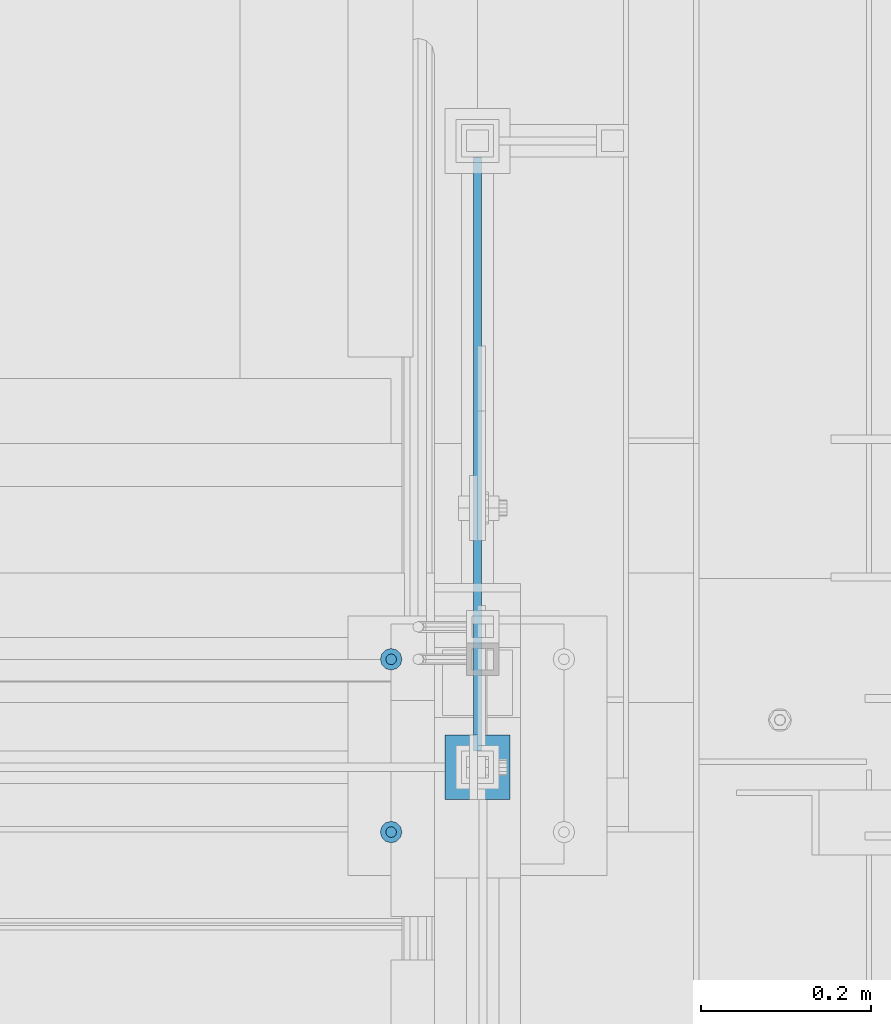
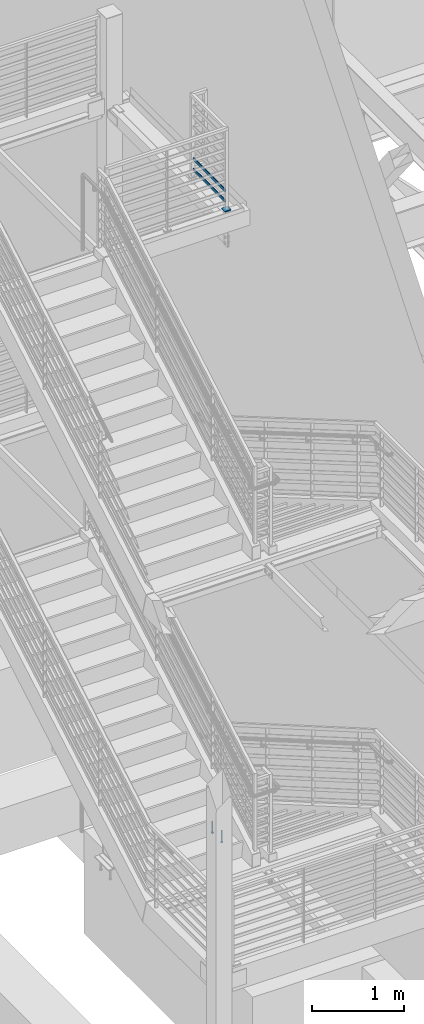
# One storey, part 873 of 1179: 5 beams, 3 elements without a shape of their own.
"""IFC2X3 building model written with IfcOpenShell, lengths in millimetres."""

import ifcopenshell
import ifcopenshell.guid

model = None  # the IFC model being written
_history = None  # IfcOwnerHistory: only IFC2X3 demands one
_inside = {}  # id of a spatial element -> (the spatial element, [elements in it])
_under = {}  # id of a project, library or spatial element -> (it, [spatial elements below it])
_declared = {}  # id of a project -> (the project, [libraries it declares])
_typed = {}  # id of a type object -> (the type object, [elements of that type])
_made_of = {}  # id of a material, layer set ... -> (it, [elements and type objects made of it])


def new_model(schema):
    """Start an empty IFC model of exactly this schema.

    Asked for "IFC4X3", IfcOpenShell would pick the latest addendum, in which some entities
    have other attributes; the version numbers below select the first issue.
    IFC2X3 requires an IfcOwnerHistory on every rooted entity: one is made here for all.
    """
    global model, _history
    if schema == "IFC4X3":
        model = ifcopenshell.file(schema_version=(4, 3, 0, 0))
    else:
        model = ifcopenshell.file(schema=schema)
    _inside.clear()
    _under.clear()
    _declared.clear()
    _typed.clear()
    _made_of.clear()
    _history = None
    if model.schema == "IFC2X3":
        org = make("IfcOrganization", Name="unknown")
        user = make(
            "IfcPersonAndOrganization",
            ThePerson=make("IfcPerson", FamilyName="unknown"),
            TheOrganization=org,
        )
        app = make(
            "IfcApplication",
            ApplicationDeveloper=org,
            Version="unknown",
            ApplicationFullName="unknown",
            ApplicationIdentifier="unknown",
        )
        _history = make(
            "IfcOwnerHistory",
            OwningUser=user,
            OwningApplication=app,
            ChangeAction="ADDED",
            CreationDate=0,
        )
    return model


def make(cls, **values):
    """One entity of the class cls with the attributes given. An attribute that is None is left unset."""
    return model.create_entity(
        cls, **{name: value for name, value in values.items() if value is not None}
    )


def rooted(cls, **values):
    """An entity with a GlobalId (a new one), such as an element, a storey or a relation."""
    return make(cls, GlobalId=ifcopenshell.guid.new(), OwnerHistory=_history, **values)


def si_unit(unit_type, name, prefix=None):
    """IfcSIUnit, for example si_unit("LENGTHUNIT", "METRE", prefix="MILLI")."""
    return make("IfcSIUnit", UnitType=unit_type, Prefix=prefix, Name=name)


def assignment(units):
    """IfcUnitAssignment: the units of a project."""
    return None if units is None else make("IfcUnitAssignment", Units=units)


def point(xyz):
    """IfcCartesianPoint."""
    return None if xyz is None else make("IfcCartesianPoint", Coordinates=xyz)


def direction(xyz):
    """IfcDirection."""
    return None if xyz is None else make("IfcDirection", DirectionRatios=xyz)


def frame(location, z_axis=None, x_axis=None):
    """IfcAxis2Placement3D, a coordinate frame: its origin and axes. An axis left out is left unset."""
    return make(
        "IfcAxis2Placement3D",
        Location=point(location),
        Axis=direction(z_axis),
        RefDirection=direction(x_axis),
    )


def origin_with_axes():
    """The frame at (0, 0, 0) with the z axis (0, 0, 1) and the x axis (1, 0, 0) written out."""
    return frame((0.0, 0.0, 0.0), z_axis=(0.0, 0.0, 1.0), x_axis=(1.0, 0.0, 0.0))


def place(relative_to, where):
    """IfcLocalPlacement: puts the frame where relative to a parent placement (None: the world)."""
    return make(
        "IfcLocalPlacement", PlacementRelTo=relative_to, RelativePlacement=where
    )


def context(
    kind, dimensions, precision=None, world=None, true_north=None, identifier=None
):
    """IfcGeometricRepresentationContext, for example the 3D "Model" context."""
    return make(
        "IfcGeometricRepresentationContext",
        ContextIdentifier=identifier,
        ContextType=kind,
        CoordinateSpaceDimension=dimensions,
        Precision=precision,
        WorldCoordinateSystem=world,
        TrueNorth=true_north,
    )


def subcontext(parent, identifier, kind, view, scale=None):
    """IfcGeometricRepresentationSubContext, for example "Body" below "Model"."""
    return make(
        "IfcGeometricRepresentationSubContext",
        ContextIdentifier=identifier,
        ContextType=kind,
        ParentContext=parent,
        TargetScale=scale,
        TargetView=view,
    )


def project(units=None, contexts=None):
    """IfcProject with its units and contexts."""
    return rooted(
        "IfcProject",
        Name="project",
        RepresentationContexts=contexts,
        UnitsInContext=assignment(units),
    )


def spatial(cls, under=None, at=None, **own):
    """A site, building, storey or space (cls), placed at a placement, below another one or the project."""
    s = rooted(cls, ObjectPlacement=at, **own)
    if under is not None:
        _under.setdefault(under.id(), (under, []))[1].append(s)
    return s


def faces_of(points, faces, orient=None, outer=None):
    """IfcFace entities. A face is a list of loops; a loop is a list of indices into points, from 0.

    orient and outer hold one flag for each loop. By default every Orientation is true, the
    first loop of a face is its IfcFaceOuterBound and the others are IfcFaceBound.
    """
    made = []
    for i, loops in enumerate(faces):
        bounds = []
        for j, loop in enumerate(loops):
            is_outer = j == 0 if outer is None else outer[i][j]
            bounds.append(
                make(
                    "IfcFaceOuterBound" if is_outer else "IfcFaceBound",
                    Bound=make("IfcPolyLoop", Polygon=[points[k] for k in loop]),
                    Orientation=True if orient is None else orient[i][j],
                )
            )
        made.append(make("IfcFace", Bounds=bounds))
    return made


def faceted_brep(points, faces, orient=None, outer=None, voids=None):
    """IfcFacetedBrep: a solid bounded by flat faces; with voids (closed shells), ...WithVoids."""
    shared = [point(p) for p in points]
    hull = make("IfcClosedShell", CfsFaces=faces_of(shared, faces, orient, outer))
    if voids is None:
        return make("IfcFacetedBrep", Outer=hull)
    return make(
        "IfcFacetedBrepWithVoids",
        Outer=hull,
        Voids=[
            make(cls, CfsFaces=faces_of(shared, fs, o, b)) for cls, fs, o, b in voids
        ],
    )


def shape(context_of_items, identifier, shape_type, items):
    """IfcShapeRepresentation: the items that make up one representation, for example the "Body"."""
    return make(
        "IfcShapeRepresentation",
        ContextOfItems=context_of_items,
        RepresentationIdentifier=identifier,
        RepresentationType=shape_type,
        Items=items,
    )


def material(Name=None, Category=None):
    """IfcMaterial."""
    return make("IfcMaterial", Name=Name, Category=Category)


def made_of(thing, what):
    """Note that an element or type object is made of a material, layer set ...; save() writes the relation."""
    if what is not None:
        _made_of.setdefault(what.id(), (what, []))[1].append(thing)
    return thing


def type_object(cls, material=None, **own):
    """A type object (cls), such as IfcWallType, which elements share."""
    return made_of(rooted(cls, **own), material)


def element(
    cls,
    number,
    at=None,
    inside=None,
    cuts=None,
    type_object=None,
    material=None,
    context=None,
    identifier="Body",
    shape_type=None,
    held_by="IfcProductDefinitionShape",
    body=None,
    shapes=None,
    **own,
):
    """One element of the class cls, such as IfcWall. Its Tag is "e" and its number.

    at: its placement. inside: the storey or other place that contains it. cuts: it is an
    opening in that element (IfcRelVoidsElement). A single representation is given by context,
    identifier, shape_type and body (its items); several are given by shapes. held_by: the class
    of the entity that holds the representations. save() writes the other relations.
    """
    e = rooted(cls, Tag="e%d" % number, ObjectPlacement=at, **own)
    if body is not None:
        shapes = [shape(context, identifier, shape_type, body)]
    if shapes is not None:
        e.Representation = make(held_by, Representations=shapes)
    if inside is not None:
        _inside.setdefault(inside.id(), (inside, []))[1].append(e)
    if cuts is not None:
        rooted(
            "IfcRelVoidsElement", RelatingBuildingElement=cuts, RelatedOpeningElement=e
        )
    if type_object is not None:
        _typed.setdefault(type_object.id(), (type_object, []))[1].append(e)
    return made_of(e, material)


def aggregate(whole, parts):
    """IfcRelAggregates: a whole, such as a stair, and the parts it consists of."""
    return rooted("IfcRelAggregates", RelatingObject=whole, RelatedObjects=parts)


def save(model, path):
    """Write the relations noted so far, then the file.

    IfcRelAggregates (storeys below a building ...), IfcRelContainedInSpatialStructure (elements
    in a storey), IfcRelDefinesByType, IfcRelAssociatesMaterial and IfcRelDeclares: one each for
    every whole, place, type object, material and project.
    """
    for whole, parts in _under.values():
        aggregate(whole, parts)
    for where, things in _inside.values():
        rooted(
            "IfcRelContainedInSpatialStructure",
            RelatedElements=things,
            RelatingStructure=where,
        )
    for kind, things in _typed.values():
        rooted("IfcRelDefinesByType", RelatedObjects=things, RelatingType=kind)
    for what, things in _made_of.values():
        rooted("IfcRelAssociatesMaterial", RelatedObjects=things, RelatingMaterial=what)
    for by, libraries in _declared.values():
        rooted("IfcRelDeclares", RelatingContext=by, RelatedDefinitions=libraries)
    model.write(path)


model = new_model("IFC2X3")

# Units and contexts
model_context = context("Model", 3, precision=1e-05, world=origin_with_axes())
body_context = subcontext(model_context, "Body", "Model", "MODEL_VIEW")
ifc_project = project(units=[si_unit("LENGTHUNIT", "METRE", prefix="MILLI"), si_unit("AREAUNIT", "SQUARE_METRE"), si_unit("VOLUMEUNIT", "CUBIC_METRE"), si_unit("MASSUNIT", "GRAM", prefix="KILO"), si_unit("TIMEUNIT", "SECOND"), si_unit("PLANEANGLEUNIT", "RADIAN"), si_unit("SOLIDANGLEUNIT", "STERADIAN"), si_unit("THERMODYNAMICTEMPERATUREUNIT", "DEGREE_CELSIUS"), si_unit("LUMINOUSINTENSITYUNIT", "LUMEN")], contexts=[model_context])

# Site, building, storey
site_placement = place(None, origin_with_axes())
site = spatial("IfcSite", under=ifc_project, at=site_placement, CompositionType="ELEMENT")
building_placement = place(site_placement, origin_with_axes())
building = spatial("IfcBuilding", under=site, at=building_placement, Name="Undefined", CompositionType="ELEMENT")
storey_placement = place(building_placement, origin_with_axes())
storey = spatial("IfcBuildingStorey", under=building, at=storey_placement, Name="Undefined", CompositionType="ELEMENT", Elevation=0.0)

# Assembly, beams
assembly_1_placement = place(storey_placement, origin_with_axes())
assembly_1 = element("IfcElementAssembly", 1, at=assembly_1_placement, inside=storey, Name="EMBED", AssemblyPlace="NOTDEFINED", PredefinedType="RIGID_FRAME")
ifc_material_1 = material(Name="STEEL/A108")
beam_type_1 = type_object("IfcBeamType", Name="STUD_1/2-DIA", PredefinedType="NOTDEFINED")
beam_1_placement = place(assembly_1_placement, frame((-355.599999997228, 35242.4999999998, -12.6999996742202), z_axis=(0.0, 1.0, 0.0), x_axis=(0.0, 0.0, -1.0)))
beam_1 = element("IfcBeam", 2, at=beam_1_placement, type_object=beam_type_1, material=ifc_material_1, Name="STUD", ObjectType="STUD_1/2-DIA", context=body_context, shape_type="Brep", body=[
    faceted_brep([(0.0, -3.1800000667572, 5.5), (0.0, -5.5, 3.1800000667572), (141.732, -5.5, 3.1800000667572), (141.732, -3.1800000667572, 5.5), (0.0, -6.34999999999854, 0.0), (141.732, -6.34999990463257, 0.0), (0.0, -5.5, -3.1800000667572), (141.732, -5.5, -3.1800000667572), (0.0, -3.1800000667572, -5.5), (141.732, -3.1800000667572, -5.5), (0.0, 0.0, -6.34999999999991), (141.732, 0.0, -6.34999990463257), (0.0, 3.1800000667572, -5.5), (141.732, 3.1800000667572, -5.5), (0.0, 5.5, -3.1800000667572), (141.732, 5.5, -3.1800000667572), (0.0, 6.34999999999854, 0.0), (141.732, 6.34999990463257, 0.0), (0.0, 5.5, 3.1800000667572), (141.732, 5.5, 3.1800000667572), (0.0, 3.1800000667572, 5.5), (141.732, 3.1800000667572, 5.5), (0.0, 0.0, 6.34999999999991), (141.732, 0.0, 6.34999990463257), (144.78, -10.9899997711182, 6.34999990463257), (144.78, -6.34000015258789, 10.9899997711182), (144.78, -12.6999998092651, 0.0), (144.78, -10.9899997711182, -6.34999990463257), (144.78, -6.34000015258789, -10.9899997711182), (144.78, 0.0, -12.6899995803833), (144.78, 6.34000015258789, -10.9899997711182), (144.78, 10.9899997711182, -6.34999990463257), (144.78, 12.6999998092651, 0.0), (144.78, 10.9899997711182, 6.34999990463257), (144.78, 6.34000015258789, 10.9899997711182), (144.78, 0.0, 12.6899995803833), (152.4, -10.9899997711182, 6.34999990463257), (152.4, -6.34000015258789, 10.9899997711182), (152.4, -12.6999998092651, 0.0), (152.4, -10.9899997711182, -6.34999990463257), (152.4, -6.34000015258789, -10.9899997711182), (152.4, 0.0, -12.6899995803833), (152.4, 6.34000015258789, -10.9899997711182), (152.4, 10.9899997711182, -6.34999990463257), (152.4, 12.6999998092651, 0.0), (152.4, 10.9899997711182, 6.34999990463257), (152.4, 6.34000015258789, 10.9899997711182), (152.4, 0.0, 12.6899995803833)], [[[0, 1, 2, 3]], [[1, 4, 5, 2]], [[4, 6, 7, 5]], [[6, 8, 9, 7]], [[8, 10, 11, 9]], [[10, 12, 13, 11]], [[12, 14, 15, 13]], [[14, 16, 17, 15]], [[16, 18, 19, 17]], [[18, 20, 21, 19]], [[20, 22, 23, 21]], [[22, 0, 3, 23]], [[22, 20, 18, 16, 14, 12, 10, 8, 6, 4, 1, 0]], [[3, 2, 24, 25]], [[2, 5, 26, 24]], [[5, 7, 27, 26]], [[7, 9, 28, 27]], [[9, 11, 29, 28]], [[11, 13, 30, 29]], [[13, 15, 31, 30]], [[15, 17, 32, 31]], [[17, 19, 33, 32]], [[19, 21, 34, 33]], [[21, 23, 35, 34]], [[23, 3, 25, 35]], [[25, 24, 36, 37]], [[24, 26, 38, 36]], [[26, 27, 39, 38]], [[27, 28, 40, 39]], [[28, 29, 41, 40]], [[29, 30, 42, 41]], [[30, 31, 43, 42]], [[31, 32, 44, 43]], [[32, 33, 45, 44]], [[33, 34, 46, 45]], [[34, 35, 47, 46]], [[35, 25, 37, 47]], [[38, 39, 40, 41, 42, 43, 44, 45, 46, 47, 37, 36]]]),
])
beam_2_placement = place(assembly_1_placement, frame((-355.599999997228, 35039.2999999998, -12.6999996742202), z_axis=(0.0, 1.0, 0.0), x_axis=(0.0, 0.0, -1.0)))
beam_2 = element("IfcBeam", 3, at=beam_2_placement, type_object=beam_type_1, material=ifc_material_1, Name="STUD", ObjectType="STUD_1/2-DIA", context=body_context, shape_type="Brep", body=[
    faceted_brep([(0.0, -3.1800000667572, 5.5), (0.0, -5.5, 3.1800000667572), (141.732, -5.5, 3.1800000667572), (141.732, -3.1800000667572, 5.5), (0.0, -6.34999999999854, 0.0), (141.732, -6.34999990463257, 0.0), (0.0, -5.5, -3.1800000667572), (141.732, -5.5, -3.1800000667572), (0.0, -3.1800000667572, -5.5), (141.732, -3.1800000667572, -5.5), (0.0, 0.0, -6.34999999999991), (141.732, 0.0, -6.34999990463257), (0.0, 3.1800000667572, -5.5), (141.732, 3.1800000667572, -5.5), (0.0, 5.5, -3.1800000667572), (141.732, 5.5, -3.1800000667572), (0.0, 6.34999999999854, 0.0), (141.732, 6.34999990463257, 0.0), (0.0, 5.5, 3.1800000667572), (141.732, 5.5, 3.1800000667572), (0.0, 3.1800000667572, 5.5), (141.732, 3.1800000667572, 5.5), (0.0, 0.0, 6.34999999999991), (141.732, 0.0, 6.34999990463257), (144.78, -10.9899997711182, 6.34999990463257), (144.78, -6.34000015258789, 10.9899997711182), (144.78, -12.6999998092651, 0.0), (144.78, -10.9899997711182, -6.34999990463257), (144.78, -6.34000015258789, -10.9899997711182), (144.78, 0.0, -12.6899995803833), (144.78, 6.34000015258789, -10.9899997711182), (144.78, 10.9899997711182, -6.34999990463257), (144.78, 12.6999998092651, 0.0), (144.78, 10.9899997711182, 6.34999990463257), (144.78, 6.34000015258789, 10.9899997711182), (144.78, 0.0, 12.6899995803833), (152.4, -10.9899997711182, 6.34999990463257), (152.4, -6.34000015258789, 10.9899997711182), (152.4, -12.6999998092651, 0.0), (152.4, -10.9899997711182, -6.34999990463257), (152.4, -6.34000015258789, -10.9899997711182), (152.4, 0.0, -12.6899995803833), (152.4, 6.34000015258789, -10.9899997711182), (152.4, 10.9899997711182, -6.34999990463257), (152.4, 12.6999998092651, 0.0), (152.4, 10.9899997711182, 6.34999990463257), (152.4, 6.34000015258789, 10.9899997711182), (152.4, 0.0, 12.6899995803833)], [[[0, 1, 2, 3]], [[1, 4, 5, 2]], [[4, 6, 7, 5]], [[6, 8, 9, 7]], [[8, 10, 11, 9]], [[10, 12, 13, 11]], [[12, 14, 15, 13]], [[14, 16, 17, 15]], [[16, 18, 19, 17]], [[18, 20, 21, 19]], [[20, 22, 23, 21]], [[22, 0, 3, 23]], [[22, 20, 18, 16, 14, 12, 10, 8, 6, 4, 1, 0]], [[3, 2, 24, 25]], [[2, 5, 26, 24]], [[5, 7, 27, 26]], [[7, 9, 28, 27]], [[9, 11, 29, 28]], [[11, 13, 30, 29]], [[13, 15, 31, 30]], [[15, 17, 32, 31]], [[17, 19, 33, 32]], [[19, 21, 34, 33]], [[21, 23, 35, 34]], [[23, 3, 25, 35]], [[25, 24, 36, 37]], [[24, 26, 38, 36]], [[26, 27, 39, 38]], [[27, 28, 40, 39]], [[28, 29, 41, 40]], [[29, 30, 42, 41]], [[30, 31, 43, 42]], [[31, 32, 44, 43]], [[32, 33, 45, 44]], [[33, 34, 46, 45]], [[34, 35, 47, 46]], [[35, 25, 37, 47]], [[38, 39, 40, 41, 42, 43, 44, 45, 46, 47, 37, 36]]]),
])
aggregate(assembly_1, [beam_1, beam_2])

assembly_2_placement = place(storey_placement, origin_with_axes())
assembly_2 = element("IfcElementAssembly", 4, at=assembly_2_placement, inside=storey, Name="GUARDRAIL", AssemblyPlace="NOTDEFINED", PredefinedType="RIGID_FRAME")
ifc_material_2 = material(Name="STEEL/A36")
beam_type_2 = type_object("IfcBeamType", PredefinedType="NOTDEFINED")
beam_3_placement = place(assembly_2_placement, frame((-253.999308360621, 35115.5, 8235.94814466621), z_axis=(0.0, 0.0, 1.0), x_axis=(0.0, 1.0, 0.0)))
beam_3 = element("IfcBeam", 5, at=beam_3_placement, type_object=beam_type_2, material=ifc_material_2, Name="PLATE", context=body_context, shape_type="Brep", body=[
    faceted_brep([(19.0499992371956, 4.76249999999709, -19.0499999999993), (19.0499992371956, 4.76249999999709, 19.0499999999993), (717.55000137195, 4.76249999999999, 19.0499999999993), (717.55000137195, 4.76249999999999, -19.0499999999993), (19.0499992371956, -4.76249999999709, 19.0499999999993), (717.55000137195, -4.76249999999999, 19.0499999999993), (19.0499992371956, -4.76249999999709, -19.0499999999993), (717.55000137195, -4.76249999999999, -19.0499999999993)], [[[0, 1, 2, 3]], [[1, 4, 5, 2]], [[4, 6, 7, 5]], [[6, 0, 3, 7]], [[5, 7, 3, 2]], [[6, 4, 1, 0]]]),
])
beam_4_placement = place(assembly_2_placement, frame((-253.999308360621, 35115.5, 8375.64814466621), z_axis=(0.0, 0.0, 1.0), x_axis=(0.0, 1.0, 0.0)))
beam_4 = element("IfcBeam", 6, at=beam_4_placement, type_object=beam_type_2, material=ifc_material_2, Name="PLATE", context=body_context, shape_type="Brep", body=[
    faceted_brep([(19.0499992371956, 4.76249999999709, -19.0499999999993), (19.0499992371956, 4.76249999999709, 19.0499999999993), (717.55000137195, 4.76249999999999, 19.0499999999993), (717.55000137195, 4.76249999999999, -19.0499999999993), (19.0499992371956, -4.76249999999709, 19.0499999999993), (717.55000137195, -4.76249999999999, 19.0499999999993), (19.0499992371956, -4.76249999999709, -19.0499999999993), (717.55000137195, -4.76249999999999, -19.0499999999993)], [[[0, 1, 2, 3]], [[1, 4, 5, 2]], [[4, 6, 7, 5]], [[6, 0, 3, 7]], [[5, 7, 3, 2]], [[6, 4, 1, 0]]]),
])
aggregate(assembly_2, [beam_3, beam_4])

# Assembly, beam
assembly_3_placement = place(storey_placement, origin_with_axes())
assembly_3 = element("IfcElementAssembly", 7, at=assembly_3_placement, inside=storey, Name="SLEEVE", AssemblyPlace="NOTDEFINED", PredefinedType="RIGID_FRAME")
beam_type_3 = type_object("IfcBeamType", PredefinedType="NOTDEFINED")
beam_5_placement = place(assembly_3_placement, frame((-292.100004637911, 35115.5, 8140.75477407027), z_axis=(0.0, 1.0, 0.0), x_axis=(1.0, 0.0, 0.0)))
beam_5 = element("IfcBeam", 8, at=beam_5_placement, type_object=beam_type_3, material=ifc_material_2, Name="PLATE", context=body_context, shape_type="Brep", body=[
    faceted_brep([(0.0, 6.35000000000036, -38.0999999999985), (0.0, 6.35000000000036, 38.0999999999985), (76.2, 6.35000000000036, 38.0999999999985), (76.2, 6.35000000000036, -38.0999999999985), (0.0, -6.35000000000036, 38.0999999999985), (76.2, -6.35000000000036, 38.0999999999985), (0.0, -6.35000000000036, -38.0999999999985), (76.2, -6.35000000000036, -38.0999999999985)], [[[0, 1, 2, 3]], [[1, 4, 5, 2]], [[4, 6, 7, 5]], [[6, 0, 3, 7]], [[5, 7, 3, 2]], [[6, 4, 1, 0]]]),
])
aggregate(assembly_3, [beam_5])

save(model, "model.ifc")
